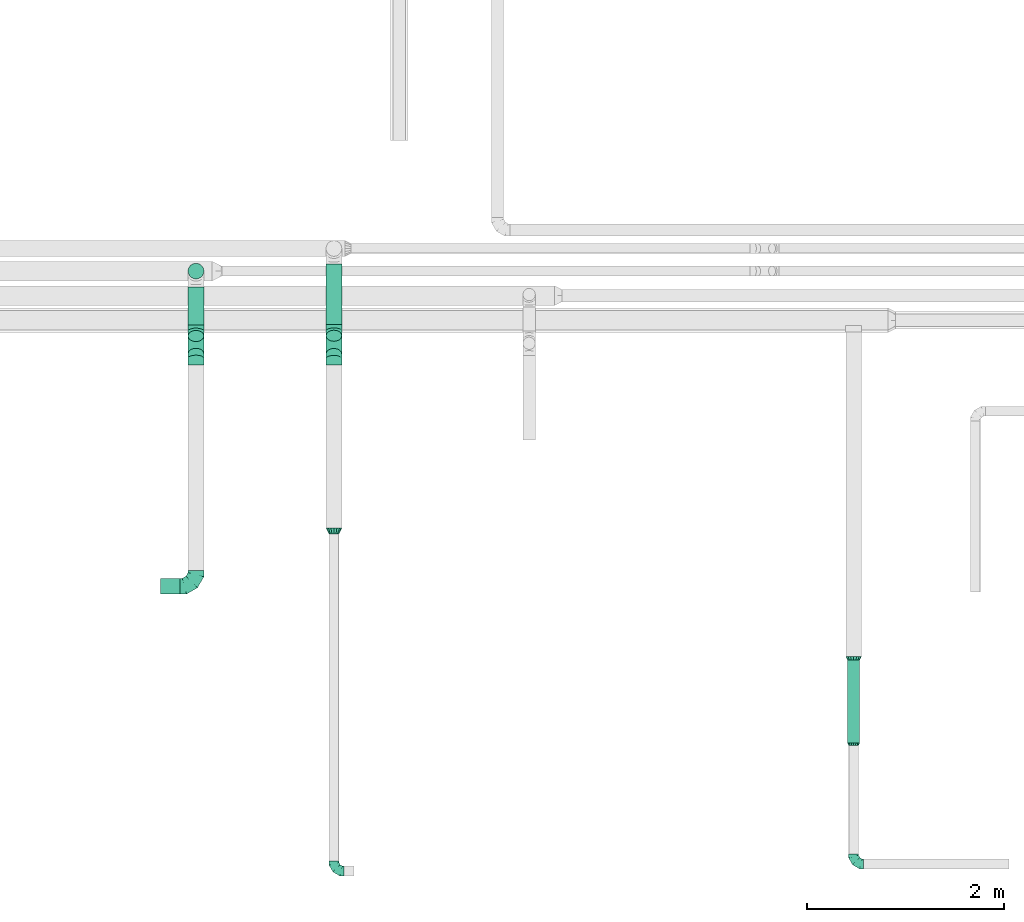
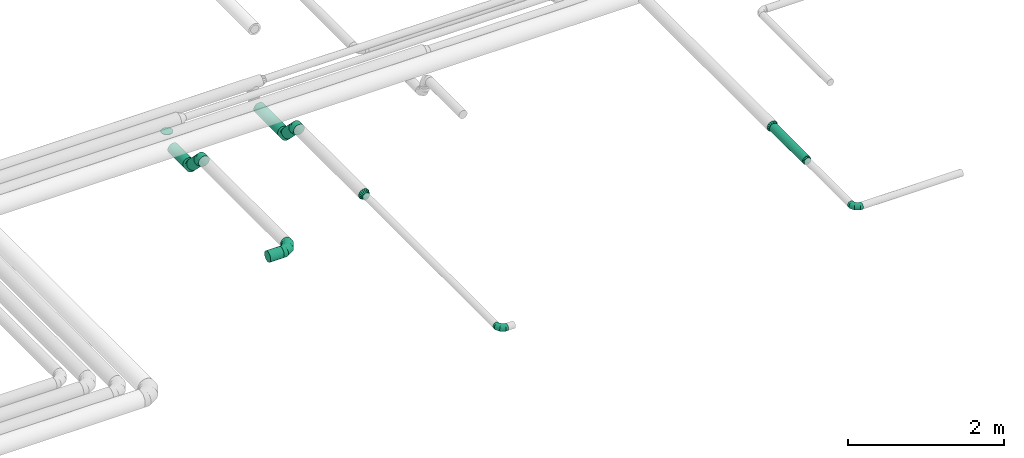
# One storey, part 51 of 92: 10 flow fittings, 7 flow segments.
"""IFC2X3 building model written with IfcOpenShell, lengths in millimetres."""

from ifc_helpers import new_model, entity, si_unit, converted_unit, derived_unit, direction, frame, origin, origin_2d_with_axis, place, context, subcontext, project, spatial, circle, extrude, faceted_brep, source, transform, mapped, material, type_object, type_shapes, element, save


model = new_model("IFC2X3")

# Units and contexts
model_context = context("Model", 3, precision=0.01, world=origin(), true_north=direction((6.12303176911189e-17, 1.0)))
body_context = subcontext(model_context, "Body", "Model", "MODEL_VIEW")
ifc_project = project(units=[si_unit("LENGTHUNIT", "METRE", prefix="MILLI"), si_unit("AREAUNIT", "SQUARE_METRE"), si_unit("VOLUMEUNIT", "CUBIC_METRE"), converted_unit("PLANEANGLEUNIT", "DEGREE", entity("IfcRatioMeasure", 0.0174532925199433), si_unit("PLANEANGLEUNIT", "RADIAN"), dimensions=[0, 0, 0, 0, 0, 0, 0]), si_unit("MASSUNIT", "GRAM", prefix="KILO"), derived_unit("MASSDENSITYUNIT", [(si_unit("MASSUNIT", "GRAM", prefix="KILO"), 1), (si_unit("LENGTHUNIT", "METRE"), -3)]), derived_unit("MOMENTOFINERTIAUNIT", [(si_unit("LENGTHUNIT", "METRE"), 4)]), si_unit("TIMEUNIT", "SECOND"), si_unit("FREQUENCYUNIT", "HERTZ"), si_unit("THERMODYNAMICTEMPERATUREUNIT", "DEGREE_CELSIUS"), derived_unit("THERMALTRANSMITTANCEUNIT", [(si_unit("MASSUNIT", "GRAM", prefix="KILO"), 1), (si_unit("THERMODYNAMICTEMPERATUREUNIT", "KELVIN"), -1), (si_unit("TIMEUNIT", "SECOND"), -3)]), derived_unit("VOLUMETRICFLOWRATEUNIT", [(si_unit("LENGTHUNIT", "METRE"), 3), (si_unit("TIMEUNIT", "SECOND"), -1)]), derived_unit("MASSFLOWRATEUNIT", [(si_unit("MASSUNIT", "GRAM", prefix="KILO"), 1), (si_unit("TIMEUNIT", "SECOND"), -1)]), derived_unit("ROTATIONALFREQUENCYUNIT", [(si_unit("TIMEUNIT", "SECOND"), -1)]), si_unit("ELECTRICCURRENTUNIT", "AMPERE"), si_unit("ELECTRICVOLTAGEUNIT", "VOLT"), si_unit("POWERUNIT", "WATT"), si_unit("FORCEUNIT", "NEWTON", prefix="KILO"), si_unit("ILLUMINANCEUNIT", "LUX"), si_unit("LUMINOUSFLUXUNIT", "LUMEN"), si_unit("LUMINOUSINTENSITYUNIT", "CANDELA"), derived_unit("USERDEFINED", [(si_unit("MASSUNIT", "GRAM", prefix="KILO"), -1), (si_unit("LENGTHUNIT", "METRE"), -2), (si_unit("TIMEUNIT", "SECOND"), 3), (si_unit("LUMINOUSFLUXUNIT", "LUMEN"), 1)]), derived_unit("LINEARVELOCITYUNIT", [(si_unit("LENGTHUNIT", "METRE"), 1), (si_unit("TIMEUNIT", "SECOND"), -1)]), si_unit("PRESSUREUNIT", "PASCAL"), derived_unit("USERDEFINED", [(si_unit("LENGTHUNIT", "METRE"), -2), (si_unit("MASSUNIT", "GRAM", prefix="KILO"), 1), (si_unit("TIMEUNIT", "SECOND"), -2)]), derived_unit("LINEARFORCEUNIT", [(si_unit("MASSUNIT", "GRAM", prefix="KILO"), 1), (si_unit("LENGTHUNIT", "METRE"), 1), (si_unit("TIMEUNIT", "SECOND"), -2), (si_unit("LENGTHUNIT", "METRE"), -1)]), derived_unit("PLANARFORCEUNIT", [(si_unit("MASSUNIT", "GRAM", prefix="KILO"), 1), (si_unit("LENGTHUNIT", "METRE"), 1), (si_unit("TIMEUNIT", "SECOND"), -2), (si_unit("LENGTHUNIT", "METRE"), -2)])], contexts=[model_context])

# Site, building, storey
site_placement = place(None, origin())
site = spatial("IfcSite", under=ifc_project, at=site_placement, CompositionType="ELEMENT")
building_placement = place(site_placement, origin())
building = spatial("IfcBuilding", under=site, at=building_placement, CompositionType="ELEMENT")
storey_placement = place(building_placement, frame((0.0, 0.0, 4200.0)))
storey = spatial("IfcBuildingStorey", under=building, at=storey_placement, CompositionType="ELEMENT", Elevation=4200.0)

# Flow segments
duct_segment_type = type_object("IfcDuctSegmentType", PredefinedType="NOTDEFINED")
flow_segment_1_placement = place(storey_placement, frame((48175.9, 1724.83, 3285.9)))
element("IfcFlowSegment", 1, at=flow_segment_1_placement, inside=storey, type_object=duct_segment_type, context=body_context, shape_type="SweptSolid", body=[
    extrude(circle(Radius=62.5, at=origin_2d_with_axis()), frame((64.1, 0.0, 64.1), z_axis=(0.0, 1.0, 0.0), x_axis=(-1.0, 0.0, 0.0)), (0.0, 0.0, 1.0), 844.999999999992),
])
flow_segment_2_placement = place(storey_placement, frame((41190.83, 3238.17, 3263.64)))
element("IfcFlowSegment", 2, at=flow_segment_2_placement, inside=storey, type_object=duct_segment_type, context=body_context, shape_type="SweptSolid", body=[
    extrude(circle(Radius=80.0, at=origin_2d_with_axis()), frame((0.0, 81.6, 81.6), z_axis=(1.0, 0.0, 0.0), x_axis=(0.0, 1.0, 0.0)), (0.0, 0.0, 1.0), 200.000000000041),
])
flow_segment_3_placement = place(storey_placement, frame((41469.24, 6443.25, 3230.0)))
element("IfcFlowSegment", 3, at=flow_segment_3_placement, inside=storey, type_object=duct_segment_type, context=body_context, shape_type="SweptSolid", body=[
    extrude(circle(Radius=80.0, at=origin_2d_with_axis()), frame((81.6, 81.6, 0.0), z_axis=(0.0, 0.0, 1.0), x_axis=(-1.0, 0.0, 0.0)), (0.0, 0.0, 1.0), 9.9999999999934),
])
flow_segment_4_placement = place(storey_placement, frame((42872.64, 5980.59, 2988.4)))
element("IfcFlowSegment", 4, at=flow_segment_4_placement, inside=storey, type_object=duct_segment_type, context=body_context, shape_type="SweptSolid", body=[
    extrude(circle(Radius=80.0, at=origin_2d_with_axis()), frame((81.6, 0.0, 81.6), z_axis=(0.0, 1.0, 0.0), x_axis=(-1.0, 0.0, 0.0)), (0.0, 0.0, 1.0), 614.445830020368),
])
flow_segment_5_placement = place(storey_placement, frame((42872.64, 5623.02, 3058.7)))
element("IfcFlowSegment", 5, at=flow_segment_5_placement, inside=storey, type_object=duct_segment_type, context=body_context, shape_type="SweptSolid", body=[
    extrude(circle(Radius=80.0, at=origin_2d_with_axis()), frame((81.6, 244.44, 58.16), z_axis=(0.0, -0.707106781186548, 0.707106781186548), x_axis=(-1.0, 0.0, 0.0)), (0.0, 0.0, 1.0), 263.431457505074),
])
flow_segment_6_placement = place(storey_placement, frame((41469.24, 5978.28, 2988.4)))
element("IfcFlowSegment", 6, at=flow_segment_6_placement, inside=storey, type_object=duct_segment_type, context=body_context, shape_type="SweptSolid", body=[
    extrude(circle(Radius=80.0, at=origin_2d_with_axis()), frame((81.6, 0.0, 81.6), z_axis=(0.0, 1.0, 0.0), x_axis=(-1.0, 0.0, 0.0)), (0.0, 0.0, 1.0), 386.565562512592),
])
flow_segment_7_placement = place(storey_placement, frame((41469.24, 5625.48, 3058.7)))
element("IfcFlowSegment", 7, at=flow_segment_7_placement, inside=storey, type_object=duct_segment_type, context=body_context, shape_type="SweptSolid", body=[
    extrude(circle(Radius=80.0, at=origin_2d_with_axis()), frame((81.6, 239.67, 58.16), z_axis=(0.0, -0.707106781186548, 0.707106781186548), x_axis=(-1.0, 0.0, 0.0)), (0.0, 0.0, 1.0), 256.688939323473),
])

# Flow fittings
ifc_material = material()
duct_fitting_type_1 = type_object("IfcDuctFittingType", PredefinedType="NOTDEFINED", material=ifc_material)
shared_shape_1 = source(origin(), body_context, "Body", "Brep", [
    faceted_brep([(-160.0, 0.0, -80.0), (-160.0, -20.71, -77.27), (-160.0, -40.0, -69.28), (-160.0, -56.57, -56.57), (-160.0, -69.28, -40.0), (-160.0, -77.27, -20.71), (-160.0, -80.0, 0.0), (-160.0, -77.27, 20.71), (-160.0, -69.28, 40.0), (-160.0, -56.57, 56.57), (-160.0, -40.0, 69.28), (-160.0, -20.71, 77.27), (-160.0, 0.0, 80.0), (-160.0, 20.71, 77.27), (-160.0, 40.0, 69.28), (-160.0, 56.57, 56.57), (-160.0, 69.28, 40.0), (-160.0, 77.27, 20.71), (-160.0, 80.0, 0.0), (-160.0, 77.27, -20.71), (-160.0, 69.28, -40.0), (-160.0, 56.57, -56.57), (-160.0, 40.0, -69.28), (-160.0, 20.71, -77.27), (-122.68, 20.71, 77.27), (-127.85, 40.0, 69.28), (-117.13, 0.0, 80.0), (-132.29, 56.57, 56.57), (-137.83, 77.27, 20.71), (-138.56, 80.0, 0.0), (-135.69, 69.28, 40.0), (-135.69, 69.28, -40.0), (-132.29, 56.57, -56.57), (-137.83, 77.27, -20.71), (-122.68, 20.71, -77.27), (-117.13, 0.0, -80.0), (-127.85, 40.0, -69.28), (-111.58, -20.71, -77.27), (-106.41, -40.0, -69.28), (-101.97, -56.57, -56.57), (-98.56, -69.28, -40.0), (-96.42, -77.27, -20.71), (-95.69, -80.0, 0.0), (-96.42, -77.27, 20.71), (-98.56, -69.28, 40.0), (-101.97, -56.57, 56.57), (-106.41, -40.0, 69.28), (-111.58, -20.71, 77.27), (-58.03, 58.03, 77.27), (-72.15, 72.15, 69.28), (-42.87, 42.87, 80.0), (-84.28, 84.28, 56.57), (-93.59, 93.59, 40.0), (-99.44, 99.44, 20.71), (-101.44, 101.44, 0.0), (-99.44, 99.44, -20.71), (-93.59, 93.59, -40.0), (-84.28, 84.28, -56.57), (-58.03, 58.03, -77.27), (-42.87, 42.87, -80.0), (-72.15, 72.15, -69.28), (-27.71, 27.71, -77.27), (-13.59, 13.59, -69.28), (-1.46, 1.46, -56.57), (7.85, -7.85, -40.0), (13.7, -13.7, -20.71), (15.69, -15.69, 0.0), (13.7, -13.7, 20.71), (7.85, -7.85, 40.0), (-1.46, 1.46, 56.57), (-13.59, 13.59, 69.28), (-27.71, 27.71, 77.27), (-20.71, 122.68, 77.27), (-40.0, 127.85, 69.28), (0.0, 117.13, 80.0), (-56.57, 132.29, 56.57), (-69.28, 135.69, 40.0), (-77.27, 137.83, 20.71), (-80.0, 138.56, 0.0), (-77.27, 137.83, -20.71), (-69.28, 135.69, -40.0), (-56.57, 132.29, -56.57), (-20.71, 122.68, -77.27), (0.0, 117.13, -80.0), (-40.0, 127.85, -69.28), (20.71, 111.58, -77.27), (40.0, 106.41, -69.28), (56.57, 101.97, -56.57), (69.28, 98.56, -40.0), (77.27, 96.42, -20.71), (80.0, 95.69, 0.0), (77.27, 96.42, 20.71), (69.28, 98.56, 40.0), (56.57, 101.97, 56.57), (40.0, 106.41, 69.28), (20.71, 111.58, 77.27), (-20.71, 160.0, -77.27), (-40.0, 160.0, -69.28), (-56.57, 160.0, -56.57), (-69.28, 160.0, -40.0), (-77.27, 160.0, -20.71), (-80.0, 160.0, 0.0), (-77.27, 160.0, 20.71), (-69.28, 160.0, 40.0), (-56.57, 160.0, 56.57), (-40.0, 160.0, 69.28), (-20.71, 160.0, 77.27), (0.0, 160.0, 80.0), (20.71, 160.0, 77.27), (40.0, 160.0, 69.28), (56.57, 160.0, 56.57), (69.28, 160.0, 40.0), (77.27, 160.0, 20.71), (80.0, 160.0, 0.0), (77.27, 160.0, -20.71), (69.28, 160.0, -40.0), (56.57, 160.0, -56.57), (40.0, 160.0, -69.28), (20.71, 160.0, -77.27), (0.0, 160.0, -80.0)], [[[0, 1, 2, 3, 4, 5, 6, 7, 8, 9, 10, 11, 12, 13, 14, 15, 16, 17, 18, 19, 20, 21, 22, 23]], [[24, 25, 14, 13]], [[26, 24, 13, 12]], [[14, 25, 27, 15]], [[28, 29, 18, 17]], [[30, 28, 17, 16]], [[15, 27, 30, 16]], [[20, 31, 32, 21]], [[33, 31, 20, 19]], [[18, 29, 33, 19]], [[34, 35, 0, 23]], [[36, 34, 23, 22]], [[32, 36, 22, 21]], [[1, 0, 35, 37]], [[2, 1, 37, 38]], [[3, 2, 38, 39]], [[5, 4, 40, 41]], [[6, 5, 41, 42]], [[39, 40, 4, 3]], [[6, 42, 43, 7]], [[7, 43, 44, 8]], [[8, 44, 45, 9]], [[9, 45, 46, 10]], [[10, 46, 47, 11]], [[26, 12, 11, 47]], [[48, 49, 25, 24]], [[50, 48, 24, 26]], [[27, 25, 49, 51]], [[52, 53, 28, 30]], [[51, 52, 30, 27]], [[29, 28, 53, 54]], [[55, 56, 31, 33]], [[54, 55, 33, 29]], [[32, 31, 56, 57]], [[58, 59, 35, 34]], [[60, 58, 34, 36]], [[57, 60, 36, 32]], [[37, 35, 59, 61]], [[38, 37, 61, 62]], [[39, 38, 62, 63]], [[41, 40, 64, 65]], [[42, 41, 65, 66]], [[63, 64, 40, 39]], [[43, 42, 66, 67]], [[44, 43, 67, 68]], [[68, 69, 45, 44]], [[46, 45, 69, 70]], [[47, 46, 70, 71]], [[26, 47, 71, 50]], [[72, 73, 49, 48]], [[74, 72, 48, 50]], [[51, 49, 73, 75]], [[76, 77, 53, 52]], [[75, 76, 52, 51]], [[54, 53, 77, 78]], [[79, 80, 56, 55]], [[78, 79, 55, 54]], [[57, 56, 80, 81]], [[82, 83, 59, 58]], [[84, 82, 58, 60]], [[81, 84, 60, 57]], [[61, 59, 83, 85]], [[62, 61, 85, 86]], [[63, 62, 86, 87]], [[65, 64, 88, 89]], [[66, 65, 89, 90]], [[87, 88, 64, 63]], [[67, 66, 90, 91]], [[68, 67, 91, 92]], [[92, 93, 69, 68]], [[70, 69, 93, 94]], [[71, 70, 94, 95]], [[50, 71, 95, 74]], [[96, 97, 98, 99, 100, 101, 102, 103, 104, 105, 106, 107, 108, 109, 110, 111, 112, 113, 114, 115, 116, 117, 118, 119]], [[72, 74, 107, 106]], [[73, 72, 106, 105]], [[75, 73, 105, 104]], [[77, 76, 103, 102]], [[78, 77, 102, 101]], [[75, 104, 103, 76]], [[78, 101, 100, 79]], [[79, 100, 99, 80]], [[80, 99, 98, 81]], [[84, 97, 96, 82]], [[82, 96, 119, 83]], [[84, 81, 98, 97]], [[118, 117, 86, 85]], [[119, 118, 85, 83]], [[116, 87, 86, 117]], [[88, 115, 114, 89]], [[89, 114, 113, 90]], [[115, 88, 87, 116]], [[112, 111, 92, 91]], [[113, 112, 91, 90]], [[111, 110, 93, 92]], [[95, 94, 109, 108]], [[74, 95, 108, 107]], [[110, 109, 94, 93]]]),
])
type_shapes(duct_fitting_type_1, [shared_shape_1])
flow_fitting_1_placement = place(storey_placement, frame((41550.83, 3319.77, 3345.23)))
element("IfcFlowFitting", 8, at=flow_fitting_1_placement, inside=storey, type_object=duct_fitting_type_1, material=ifc_material, context=body_context, shape_type="MappedRepresentation", body=[
    mapped(shared_shape_1, transform((0.0, 0.0, 0.0), scale=1.0)),
])
duct_fitting_type_2 = type_object("IfcDuctFittingType", PredefinedType="NOTDEFINED", material=ifc_material)
shared_shape_2 = source(origin(), body_context, "Body", "Brep", [
    faceted_brep([(-100.0, 0.0, -50.0), (-100.0, -12.94, -48.3), (-100.0, -25.0, -43.3), (-100.0, -35.36, -35.36), (-100.0, -43.3, -25.0), (-100.0, -48.3, -12.94), (-100.0, -50.0, 0.0), (-100.0, -48.3, 12.94), (-100.0, -43.3, 25.0), (-100.0, -35.36, 35.36), (-100.0, -25.0, 43.3), (-100.0, -12.94, 48.3), (-100.0, 0.0, 50.0), (-100.0, 12.94, 48.3), (-100.0, 25.0, 43.3), (-100.0, 35.36, 35.36), (-100.0, 43.3, 25.0), (-100.0, 48.3, 12.94), (-100.0, 50.0, 0.0), (-100.0, 48.3, -12.94), (-100.0, 43.3, -25.0), (-100.0, 35.36, -35.36), (-100.0, 25.0, -43.3), (-100.0, 12.94, -48.3), (-76.67, 12.94, 48.3), (-79.9, 25.0, 43.3), (-73.21, 0.0, 50.0), (-82.68, 35.36, 35.36), (-86.15, 48.3, 12.94), (-86.6, 50.0, 0.0), (-84.81, 43.3, 25.0), (-84.81, 43.3, -25.0), (-82.68, 35.36, -35.36), (-86.15, 48.3, -12.94), (-76.67, 12.94, -48.3), (-73.21, 0.0, -50.0), (-79.9, 25.0, -43.3), (-69.74, -12.94, -48.3), (-66.51, -25.0, -43.3), (-63.73, -35.36, -35.36), (-61.6, -43.3, -25.0), (-60.26, -48.3, -12.94), (-59.81, -50.0, 0.0), (-60.26, -48.3, 12.94), (-61.6, -43.3, 25.0), (-63.73, -35.36, 35.36), (-66.51, -25.0, 43.3), (-69.74, -12.94, 48.3), (-36.27, 36.27, 48.3), (-45.1, 45.1, 43.3), (-26.79, 26.79, 50.0), (-52.68, 52.68, 35.36), (-58.49, 58.49, 25.0), (-62.15, 62.15, 12.94), (-63.4, 63.4, 0.0), (-62.15, 62.15, -12.94), (-58.49, 58.49, -25.0), (-52.68, 52.68, -35.36), (-36.27, 36.27, -48.3), (-26.79, 26.79, -50.0), (-45.1, 45.1, -43.3), (-17.32, 17.32, -48.3), (-8.49, 8.49, -43.3), (-0.91, 0.91, -35.36), (4.9, -4.9, -25.0), (8.56, -8.56, -12.94), (9.81, -9.81, 0.0), (8.56, -8.56, 12.94), (4.9, -4.9, 25.0), (-0.91, 0.91, 35.36), (-8.49, 8.49, 43.3), (-17.32, 17.32, 48.3), (-12.94, 76.67, 48.3), (-25.0, 79.9, 43.3), (0.0, 73.21, 50.0), (-35.36, 82.68, 35.36), (-43.3, 84.81, 25.0), (-48.3, 86.15, 12.94), (-50.0, 86.6, 0.0), (-48.3, 86.15, -12.94), (-43.3, 84.81, -25.0), (-35.36, 82.68, -35.36), (-12.94, 76.67, -48.3), (0.0, 73.21, -50.0), (-25.0, 79.9, -43.3), (12.94, 69.74, -48.3), (25.0, 66.51, -43.3), (35.36, 63.73, -35.36), (43.3, 61.6, -25.0), (48.3, 60.26, -12.94), (50.0, 59.81, 0.0), (48.3, 60.26, 12.94), (43.3, 61.6, 25.0), (35.36, 63.73, 35.36), (25.0, 66.51, 43.3), (12.94, 69.74, 48.3), (-12.94, 100.0, -48.3), (-25.0, 100.0, -43.3), (-35.36, 100.0, -35.36), (-43.3, 100.0, -25.0), (-48.3, 100.0, -12.94), (-50.0, 100.0, 0.0), (-48.3, 100.0, 12.94), (-43.3, 100.0, 25.0), (-35.36, 100.0, 35.36), (-25.0, 100.0, 43.3), (-12.94, 100.0, 48.3), (0.0, 100.0, 50.0), (12.94, 100.0, 48.3), (25.0, 100.0, 43.3), (35.36, 100.0, 35.36), (43.3, 100.0, 25.0), (48.3, 100.0, 12.94), (50.0, 100.0, 0.0), (48.3, 100.0, -12.94), (43.3, 100.0, -25.0), (35.36, 100.0, -35.36), (25.0, 100.0, -43.3), (12.94, 100.0, -48.3), (0.0, 100.0, -50.0)], [[[0, 1, 2, 3, 4, 5, 6, 7, 8, 9, 10, 11, 12, 13, 14, 15, 16, 17, 18, 19, 20, 21, 22, 23]], [[24, 25, 14, 13]], [[26, 24, 13, 12]], [[14, 25, 27, 15]], [[28, 29, 18, 17]], [[30, 28, 17, 16]], [[15, 27, 30, 16]], [[20, 31, 32, 21]], [[33, 31, 20, 19]], [[18, 29, 33, 19]], [[34, 35, 0, 23]], [[36, 34, 23, 22]], [[32, 36, 22, 21]], [[2, 1, 37, 38]], [[3, 2, 38, 39]], [[0, 35, 37, 1]], [[5, 4, 40, 41]], [[6, 5, 41, 42]], [[3, 39, 40, 4]], [[6, 42, 43, 7]], [[7, 43, 44, 8]], [[8, 44, 45, 9]], [[10, 46, 47, 11]], [[11, 47, 26, 12]], [[10, 9, 45, 46]], [[48, 49, 25, 24]], [[50, 48, 24, 26]], [[27, 25, 49, 51]], [[52, 53, 28, 30]], [[51, 52, 30, 27]], [[29, 28, 53, 54]], [[55, 56, 31, 33]], [[54, 55, 33, 29]], [[57, 32, 31, 56]], [[58, 59, 35, 34]], [[60, 58, 34, 36]], [[57, 60, 36, 32]], [[37, 35, 59, 61]], [[38, 37, 61, 62]], [[39, 38, 62, 63]], [[41, 40, 64, 65]], [[42, 41, 65, 66]], [[63, 64, 40, 39]], [[43, 42, 66, 67]], [[44, 43, 67, 68]], [[68, 69, 45, 44]], [[46, 45, 69, 70]], [[47, 46, 70, 71]], [[26, 47, 71, 50]], [[72, 73, 49, 48]], [[74, 72, 48, 50]], [[51, 49, 73, 75]], [[76, 77, 53, 52]], [[75, 76, 52, 51]], [[54, 53, 77, 78]], [[79, 80, 56, 55]], [[78, 79, 55, 54]], [[81, 57, 56, 80]], [[82, 83, 59, 58]], [[84, 82, 58, 60]], [[81, 84, 60, 57]], [[61, 59, 83, 85]], [[62, 61, 85, 86]], [[63, 62, 86, 87]], [[65, 64, 88, 89]], [[66, 65, 89, 90]], [[87, 88, 64, 63]], [[67, 66, 90, 91]], [[68, 67, 91, 92]], [[92, 93, 69, 68]], [[70, 69, 93, 94]], [[71, 70, 94, 95]], [[50, 71, 95, 74]], [[96, 97, 98, 99, 100, 101, 102, 103, 104, 105, 106, 107, 108, 109, 110, 111, 112, 113, 114, 115, 116, 117, 118, 119]], [[72, 74, 107, 106]], [[73, 72, 106, 105]], [[75, 73, 105, 104]], [[77, 76, 103, 102]], [[78, 77, 102, 101]], [[75, 104, 103, 76]], [[78, 101, 100, 79]], [[79, 100, 99, 80]], [[80, 99, 98, 81]], [[96, 119, 83, 82]], [[97, 96, 82, 84]], [[84, 81, 98, 97]], [[83, 119, 118, 85]], [[85, 118, 117, 86]], [[86, 117, 116, 87]], [[88, 115, 114, 89]], [[89, 114, 113, 90]], [[87, 116, 115, 88]], [[91, 90, 113, 112]], [[92, 91, 112, 111]], [[93, 92, 111, 110]], [[95, 94, 109, 108]], [[74, 95, 108, 107]], [[110, 109, 94, 93]]]),
])
type_shapes(duct_fitting_type_2, [shared_shape_2])
for number, where, z_axis, x_axis in (
    (9, (42954.24, 423.14, 3350.0), (0.0, 0.0, 1.0), (0.0, -1.0, 0.0)),
    (10, (48240.0, 495.45, 3350.0), (0.0, 0.0, 1.0), (0.0, -1.0, 0.0)),
):
    element("IfcFlowFitting", number, at=place(storey_placement, frame(where, z_axis=z_axis, x_axis=x_axis)), inside=storey, type_object=duct_fitting_type_2, material=ifc_material, context=body_context, shape_type="MappedRepresentation", body=[
        mapped(shared_shape_2, transform((0.0, 0.0, 0.0), scale=1.0)),
    ])
duct_fitting_type_3 = type_object("IfcDuctFittingType", PredefinedType="NOTDEFINED", material=ifc_material)
shared_shape_3 = source(origin(), body_context, "Body", "Brep", [
    faceted_brep([(-66.27, 0.0, -80.0), (-66.27, -20.71, -77.27), (-66.27, -40.0, -69.28), (-66.27, -56.57, -56.57), (-66.27, -69.28, -40.0), (-66.27, -77.27, -20.71), (-66.27, -80.0, 0.0), (-66.27, -77.27, 20.71), (-66.27, -69.28, 40.0), (-66.27, -56.57, 56.57), (-66.27, -40.0, 69.28), (-66.27, -20.71, 77.27), (-66.27, 0.0, 80.0), (-66.27, 20.71, 77.27), (-66.27, 40.0, 69.28), (-66.27, 56.57, 56.57), (-66.27, 69.28, 40.0), (-66.27, 77.27, 20.71), (-66.27, 80.0, 0.0), (-66.27, 77.27, -20.71), (-66.27, 69.28, -40.0), (-66.27, 56.57, -56.57), (-66.27, 40.0, -69.28), (-66.27, 20.71, -77.27), (-8.58, 20.71, 77.27), (-16.57, 40.0, 69.28), (0.0, 0.0, 80.0), (-23.43, 56.57, 56.57), (-28.7, 69.28, 40.0), (-32.01, 77.27, 20.71), (-33.14, 80.0, 0.0), (-32.01, 77.27, -20.71), (-28.7, 69.28, -40.0), (-23.43, 56.57, -56.57), (-8.58, 20.71, -77.27), (0.0, 0.0, -80.0), (-16.57, 40.0, -69.28), (8.58, -20.71, -77.27), (16.57, -40.0, -69.28), (23.43, -56.57, -56.57), (28.7, -69.28, -40.0), (32.01, -77.27, -20.71), (33.14, -80.0, 0.0), (32.01, -77.27, 20.71), (28.7, -69.28, 40.0), (23.43, -56.57, 56.57), (16.57, -40.0, 69.28), (8.58, -20.71, 77.27), (46.86, 46.86, 80.0), (32.22, 61.5, 77.27), (18.58, 75.15, 69.28), (6.86, 86.86, 56.57), (-2.13, 95.85, 40.0), (-7.78, 101.5, 20.71), (-9.71, 103.43, 0.0), (-7.78, 101.5, -20.71), (-2.13, 95.85, -40.0), (6.86, 86.86, -56.57), (18.58, 75.15, -69.28), (32.22, 61.5, -77.27), (46.86, 46.86, -80.0), (61.5, 32.22, -77.27), (75.15, 18.58, -69.28), (86.86, 6.86, -56.57), (95.85, -2.13, -40.0), (101.5, -7.78, -20.71), (103.43, -9.71, 0.0), (101.5, -7.78, 20.71), (95.85, -2.13, 40.0), (86.86, 6.86, 56.57), (75.15, 18.58, 69.28), (61.5, 32.22, 77.27)], [[[0, 1, 2, 3, 4, 5, 6, 7, 8, 9, 10, 11, 12, 13, 14, 15, 16, 17, 18, 19, 20, 21, 22, 23]], [[24, 25, 14, 13]], [[26, 24, 13, 12]], [[14, 25, 27, 15]], [[28, 29, 17, 16]], [[28, 16, 15, 27]], [[30, 18, 17, 29]], [[31, 32, 20, 19]], [[30, 31, 19, 18]], [[32, 33, 21, 20]], [[34, 35, 0, 23]], [[36, 34, 23, 22]], [[33, 36, 22, 21]], [[1, 0, 35, 37]], [[2, 1, 37, 38]], [[38, 39, 3, 2]], [[5, 4, 40, 41]], [[6, 5, 41, 42]], [[39, 40, 4, 3]], [[6, 42, 43, 7]], [[7, 43, 44, 8]], [[8, 44, 45, 9]], [[9, 45, 46, 10]], [[10, 46, 47, 11]], [[26, 12, 11, 47]], [[24, 26, 48, 49]], [[25, 24, 49, 50]], [[27, 25, 50, 51]], [[29, 28, 52, 53]], [[30, 29, 53, 54]], [[51, 52, 28, 27]], [[30, 54, 55, 31]], [[31, 55, 56, 32]], [[57, 33, 32, 56]], [[36, 58, 59, 34]], [[34, 59, 60, 35]], [[58, 36, 33, 57]], [[35, 60, 61, 37]], [[37, 61, 62, 38]], [[63, 39, 38, 62]], [[40, 64, 65, 41]], [[41, 65, 66, 42]], [[64, 40, 39, 63]], [[43, 42, 66, 67]], [[44, 43, 67, 68]], [[68, 69, 45, 44]], [[47, 46, 70, 71]], [[26, 47, 71, 48]], [[69, 70, 46, 45]], [[59, 58, 57, 56, 55, 54, 53, 52, 51, 50, 49, 48, 71, 70, 69, 68, 67, 66, 65, 64, 63, 62, 61, 60]]]),
])
type_shapes(duct_fitting_type_3, [shared_shape_3])
for number, where, z_axis, x_axis in (
    (11, (42954.24, 5914.32, 3070.0), (-1.0, 0.0, 0.0), (0.0, -1.0, 0.0)),
    (12, (42954.24, 5634.32, 3350.0), (1.0, 0.0, 0.0), (0.0, -0.707106781186503, 0.707106781186592)),
    (13, (41550.83, 5912.01, 3070.0), (-1.0, 0.0, 0.0), (0.0, -1.0, 0.0)),
    (14, (41550.83, 5636.78, 3345.23), (1.0, 0.0, 0.0), (0.0, -0.707106781186504, 0.707106781186591)),
):
    element("IfcFlowFitting", number, at=place(storey_placement, frame(where, z_axis=z_axis, x_axis=x_axis)), inside=storey, type_object=duct_fitting_type_3, material=ifc_material, context=body_context, shape_type="MappedRepresentation", body=[
        mapped(shared_shape_3, transform((0.0, 0.0, 0.0), scale=1.0)),
    ])
duct_fitting_type_4 = type_object("IfcDuctFittingType", PredefinedType="NOTDEFINED", material=ifc_material)
shared_shape_4 = source(origin(), body_context, "Body", "Brep", [
    faceted_brep([(35.0, 0.0, -80.0), (35.0, 12.81, -77.45), (35.0, 30.61, -73.91), (35.0, 43.59, -65.24), (35.0, 56.57, -56.57), (35.0, 65.24, -43.59), (35.0, 73.91, -30.61), (35.0, 76.96, -15.31), (35.0, 80.0, 0.0), (35.0, 77.45, 12.81), (35.0, 73.91, 30.61), (35.0, 65.24, 43.59), (35.0, 56.57, 56.57), (35.0, 43.59, 65.24), (35.0, 30.61, 73.91), (35.0, 15.31, 76.96), (35.0, 0.0, 80.0), (35.0, -12.81, 77.45), (35.0, -30.61, 73.91), (35.0, -43.59, 65.24), (35.0, -56.57, 56.57), (35.0, -65.24, 43.59), (35.0, -73.91, 30.61), (35.0, -76.96, 15.31), (35.0, -80.0, 0.0), (35.0, -77.45, -12.81), (35.0, -73.91, -30.61), (35.0, -65.24, -43.59), (35.0, -56.57, -56.57), (35.0, -43.59, -65.24), (35.0, -30.61, -73.91), (35.0, -15.31, -76.96), (0.0, -23.92, -57.74), (0.0, -34.06, -50.97), (0.0, -44.19, -44.19), (0.0, -50.97, -34.06), (0.0, -57.74, -23.92), (0.0, -60.12, -11.96), (0.0, -62.5, 0.0), (0.0, -60.12, 11.96), (0.0, -57.74, 23.92), (0.0, -50.97, 34.06), (0.0, -44.19, 44.19), (0.0, -34.06, 50.97), (0.0, -23.92, 57.74), (0.0, -11.96, 60.12), (0.0, 0.0, 62.5), (0.0, 11.96, 60.12), (0.0, 23.92, 57.74), (0.0, 34.06, 50.97), (0.0, 44.19, 44.19), (0.0, 50.97, 34.06), (0.0, 57.74, 23.92), (0.0, 60.12, 11.96), (0.0, 62.5, 0.0), (0.0, 60.12, -11.96), (0.0, 57.74, -23.92), (0.0, 50.97, -34.06), (0.0, 44.19, -44.19), (0.0, 34.06, -50.97), (0.0, 23.92, -57.74), (0.0, 11.96, -60.12), (0.0, 0.0, -62.5), (0.0, -11.96, -60.12)], [[[0, 1, 2, 3, 4, 5, 6, 7, 8, 9, 10, 11, 12, 13, 14, 15, 16, 17, 18, 19, 20, 21, 22, 23, 24, 25, 26, 27, 28, 29, 30, 31]], [[32, 33, 34, 35, 36, 37, 38, 39, 40, 41, 42, 43, 44, 45, 46, 47, 48, 49, 50, 51, 52, 53, 54, 55, 56, 57, 58, 59, 60, 61, 62, 63]], [[10, 9, 8, 54, 53, 52]], [[11, 10, 52, 51, 50, 12]], [[48, 14, 13, 12, 50, 49]], [[46, 16, 15, 14, 48, 47]], [[18, 17, 16, 46, 45, 44]], [[19, 18, 44, 43, 42, 20]], [[40, 22, 21, 20, 42, 41]], [[38, 24, 23, 22, 40, 39]], [[26, 25, 24, 38, 37, 36]], [[27, 26, 36, 35, 34, 28]], [[32, 30, 29, 28, 34, 33]], [[62, 0, 31, 30, 32, 63]], [[2, 1, 0, 62, 61, 60]], [[3, 2, 60, 59, 58, 4]], [[56, 6, 5, 4, 58, 57]], [[54, 8, 7, 6, 56, 55]]]),
])
type_shapes(duct_fitting_type_4, [shared_shape_4])
flow_fitting_2_placement = place(storey_placement, frame((48240.0, 2569.83, 3350.0), z_axis=(0.0, 0.0, 1.0), x_axis=(0.0, 1.0, 0.0)))
element("IfcFlowFitting", 15, at=flow_fitting_2_placement, inside=storey, type_object=duct_fitting_type_4, material=ifc_material, context=body_context, shape_type="MappedRepresentation", body=[
    mapped(shared_shape_4, transform((0.0, 0.0, 0.0), scale=1.0)),
])
duct_fitting_type_5 = type_object("IfcDuctFittingType", PredefinedType="NOTDEFINED", material=ifc_material)
shared_shape_5 = source(origin(), body_context, "Body", "Brep", [
    faceted_brep([(25.0, -46.19, 19.13), (25.0, -48.1, 9.57), (25.0, -50.0, 0.0), (25.0, -48.1, -9.57), (25.0, -46.19, -19.13), (25.0, -40.77, -27.24), (25.0, -35.36, -35.36), (25.0, -27.24, -40.77), (25.0, -19.13, -46.19), (25.0, -9.57, -48.1), (25.0, 0.0, -50.0), (25.0, 9.57, -48.1), (25.0, 19.13, -46.19), (25.0, 27.24, -40.77), (25.0, 35.36, -35.36), (25.0, 40.77, -27.24), (25.0, 46.19, -19.13), (25.0, 48.1, -9.57), (25.0, 50.0, 0.0), (25.0, 48.1, 9.57), (25.0, 46.19, 19.13), (25.0, 40.77, 27.24), (25.0, 35.36, 35.36), (25.0, 27.24, 40.77), (25.0, 19.13, 46.19), (25.0, 9.57, 48.1), (25.0, 0.0, 50.0), (25.0, -9.57, 48.1), (25.0, -19.13, 46.19), (25.0, -27.24, 40.77), (25.0, -35.36, 35.36), (25.0, -40.77, 27.24), (0.0, -62.5, 0.0), (0.0, -60.02, 12.45), (0.0, -57.74, 23.92), (0.0, -50.97, 34.06), (0.0, -44.19, 44.19), (0.0, -34.06, 50.97), (0.0, -23.92, 57.74), (0.0, -12.45, 60.02), (0.0, 0.0, 62.5), (0.0, 12.45, 60.02), (0.0, 23.92, 57.74), (0.0, 34.06, 50.97), (0.0, 44.19, 44.19), (0.0, 50.97, 34.06), (0.0, 57.74, 23.92), (0.0, 60.02, 12.45), (0.0, 62.5, 0.0), (0.0, 60.02, -12.45), (0.0, 57.74, -23.92), (0.0, 50.97, -34.06), (0.0, 44.19, -44.19), (0.0, 34.06, -50.97), (0.0, 23.92, -57.74), (0.0, 12.45, -60.02), (0.0, 0.0, -62.5), (0.0, -12.45, -60.02), (0.0, -23.92, -57.74), (0.0, -34.06, -50.97), (0.0, -44.19, -44.19), (0.0, -50.97, -34.06), (0.0, -57.74, -23.92), (0.0, -60.02, -12.45)], [[[0, 1, 2, 3, 4, 5, 6, 7, 8, 9, 10, 11, 12, 13, 14, 15, 16, 17, 18, 19, 20, 21, 22, 23, 24, 25, 26, 27, 28, 29, 30, 31]], [[32, 33, 34, 35, 36, 37, 38, 39, 40, 41, 42, 43, 44, 45, 46, 47, 48, 49, 50, 51, 52, 53, 54, 55, 56, 57, 58, 59, 60, 61, 62, 63]], [[24, 42, 41, 40, 26, 25]], [[22, 44, 43, 42, 24, 23]], [[48, 47, 46, 20, 19, 18]], [[44, 22, 21, 20, 46, 45]], [[0, 34, 33, 32, 2, 1]], [[30, 36, 35, 34, 0, 31]], [[40, 39, 38, 28, 27, 26]], [[36, 30, 29, 28, 38, 37]], [[8, 58, 57, 56, 10, 9]], [[6, 60, 59, 58, 8, 7]], [[32, 63, 62, 4, 3, 2]], [[60, 6, 5, 4, 62, 61]], [[16, 50, 49, 48, 18, 17]], [[14, 52, 51, 50, 16, 15]], [[56, 55, 54, 12, 11, 10]], [[52, 14, 13, 12, 54, 53]]]),
])
type_shapes(duct_fitting_type_5, [shared_shape_5])
flow_fitting_3_placement = place(storey_placement, frame((48240.0, 1724.83, 3350.0), z_axis=(0.0, 0.0, 1.0), x_axis=(0.0, -1.0, 0.0)))
element("IfcFlowFitting", 16, at=flow_fitting_3_placement, inside=storey, type_object=duct_fitting_type_5, material=ifc_material, context=body_context, shape_type="MappedRepresentation", body=[
    mapped(shared_shape_5, transform((0.0, 0.0, 0.0), scale=1.0)),
])
duct_fitting_type_6 = type_object("IfcDuctFittingType", PredefinedType="NOTDEFINED", material=ifc_material)
shared_shape_6 = source(origin(), body_context, "Body", "Brep", [
    faceted_brep([(60.0, 0.0, -80.0), (60.0, 14.27, -77.16), (60.0, 30.61, -73.91), (60.0, 43.59, -65.24), (60.0, 56.57, -56.57), (60.0, 65.24, -43.59), (60.0, 73.91, -30.61), (60.0, 77.16, -14.27), (60.0, 80.0, 0.0), (60.0, 77.16, 14.27), (60.0, 73.91, 30.61), (60.0, 65.24, 43.59), (60.0, 56.57, 56.57), (60.0, 43.59, 65.24), (60.0, 30.61, 73.91), (60.0, 14.27, 77.16), (60.0, 0.0, 80.0), (60.0, -14.27, 77.16), (60.0, -30.61, 73.91), (60.0, -43.59, 65.24), (60.0, -56.57, 56.57), (60.0, -65.24, 43.59), (60.0, -73.91, 30.61), (60.0, -77.16, 14.27), (60.0, -80.0, 0.0), (60.0, -77.16, -14.27), (60.0, -73.91, -30.61), (60.0, -65.24, -43.59), (60.0, -56.57, -56.57), (60.0, -43.59, -65.24), (60.0, -30.61, -73.91), (60.0, -14.27, -77.16), (0.0, -19.13, -46.19), (0.0, -27.24, -40.77), (0.0, -35.36, -35.36), (0.0, -40.77, -27.24), (0.0, -46.19, -19.13), (0.0, -48.1, -9.57), (0.0, -50.0, 0.0), (0.0, -48.1, 9.57), (0.0, -46.19, 19.13), (0.0, -40.77, 27.24), (0.0, -35.36, 35.36), (0.0, -27.24, 40.77), (0.0, -19.13, 46.19), (0.0, -9.57, 48.1), (0.0, 0.0, 50.0), (0.0, 9.57, 48.1), (0.0, 19.13, 46.19), (0.0, 27.24, 40.77), (0.0, 35.36, 35.36), (0.0, 40.77, 27.24), (0.0, 46.19, 19.13), (0.0, 48.1, 9.57), (0.0, 50.0, 0.0), (0.0, 48.1, -9.57), (0.0, 46.19, -19.13), (0.0, 40.77, -27.24), (0.0, 35.36, -35.36), (0.0, 27.24, -40.77), (0.0, 19.13, -46.19), (0.0, 9.57, -48.1), (0.0, 0.0, -50.0), (0.0, -9.57, -48.1)], [[[0, 1, 2, 3, 4, 5, 6, 7, 8, 9, 10, 11, 12, 13, 14, 15, 16, 17, 18, 19, 20, 21, 22, 23, 24, 25, 26, 27, 28, 29, 30, 31]], [[32, 33, 34, 35, 36, 37, 38, 39, 40, 41, 42, 43, 44, 45, 46, 47, 48, 49, 50, 51, 52, 53, 54, 55, 56, 57, 58, 59, 60, 61, 62, 63]], [[52, 51, 50, 12, 11, 10]], [[48, 14, 13, 12, 50, 49]], [[10, 9, 8, 54, 53, 52]], [[15, 14, 48, 47, 46, 16]], [[44, 43, 42, 20, 19, 18]], [[40, 22, 21, 20, 42, 41]], [[18, 17, 16, 46, 45, 44]], [[23, 22, 40, 39, 38, 24]], [[36, 35, 34, 28, 27, 26]], [[32, 30, 29, 28, 34, 33]], [[26, 25, 24, 38, 37, 36]], [[31, 30, 32, 63, 62, 0]], [[60, 59, 58, 4, 3, 2]], [[56, 6, 5, 4, 58, 57]], [[2, 1, 0, 62, 61, 60]], [[7, 6, 56, 55, 54, 8]]]),
])
type_shapes(duct_fitting_type_6, [shared_shape_6])
flow_fitting_4_placement = place(storey_placement, frame((42954.24, 3850.04, 3350.0), z_axis=(0.0, 0.0, 1.0), x_axis=(0.0, 1.0, 0.0)))
element("IfcFlowFitting", 17, at=flow_fitting_4_placement, inside=storey, type_object=duct_fitting_type_6, material=ifc_material, context=body_context, shape_type="MappedRepresentation", body=[
    mapped(shared_shape_6, transform((0.0, 0.0, 0.0), scale=1.0)),
])

save(model, "model.ifc")
